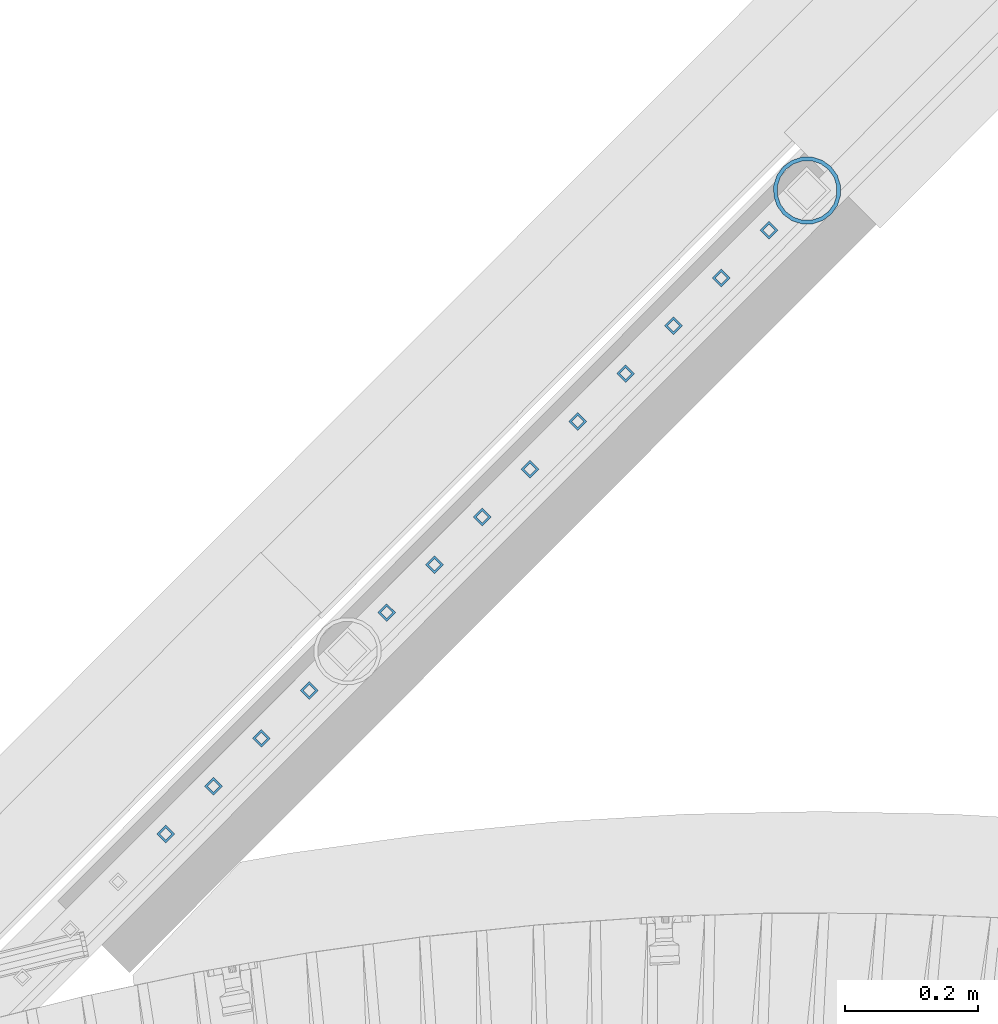
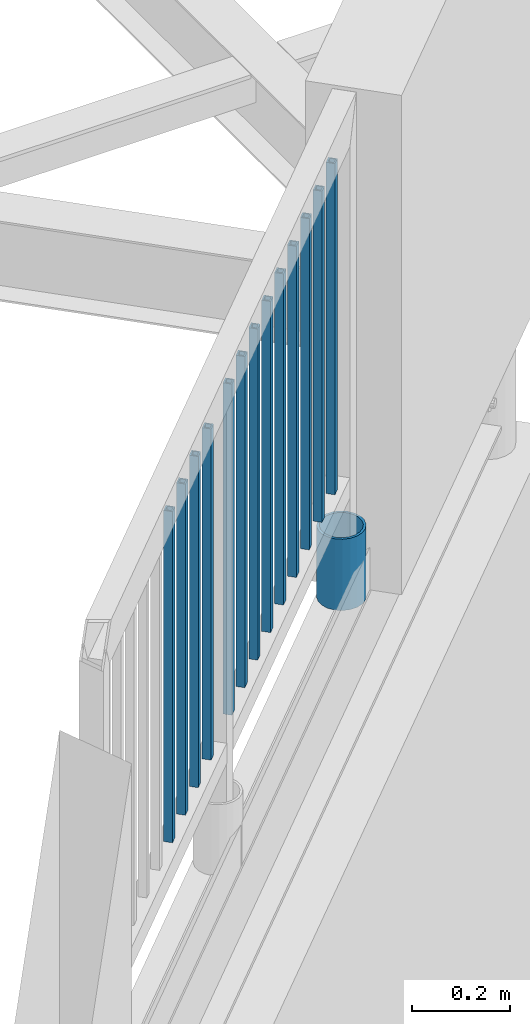
# One storey, part 273 of 975: 14 columns.
"""IFC2X3 building model written with IfcOpenShell, lengths in millimetres."""

from ifc_helpers import new_model, si_unit, frame, origin_with_axes, place, context, subcontext, project, spatial, faceted_brep, material, type_object, element, save


model = new_model("IFC2X3")

# Units and contexts
model_context = context("Model", 3, precision=1e-05, world=origin_with_axes())
body_context = subcontext(model_context, "Body", "Model", "MODEL_VIEW")
ifc_project = project(units=[si_unit("LENGTHUNIT", "METRE", prefix="MILLI"), si_unit("AREAUNIT", "SQUARE_METRE"), si_unit("VOLUMEUNIT", "CUBIC_METRE"), si_unit("MASSUNIT", "GRAM", prefix="KILO"), si_unit("TIMEUNIT", "SECOND"), si_unit("PLANEANGLEUNIT", "RADIAN"), si_unit("SOLIDANGLEUNIT", "STERADIAN"), si_unit("THERMODYNAMICTEMPERATUREUNIT", "DEGREE_CELSIUS"), si_unit("LUMINOUSINTENSITYUNIT", "LUMEN")], contexts=[model_context])

# Site, building, storey
site_placement = place(None, origin_with_axes())
site = spatial("IfcSite", under=ifc_project, at=site_placement, CompositionType="ELEMENT")
building_placement = place(site_placement, origin_with_axes())
building = spatial("IfcBuilding", under=site, at=building_placement, Name="Undefined", CompositionType="ELEMENT")
storey_placement = place(building_placement, origin_with_axes())
storey = spatial("IfcBuildingStorey", under=building, at=storey_placement, Name="Undefined", CompositionType="ELEMENT", Elevation=0.0)

# Columns
ifc_material_1 = material()
column_type_1 = type_object("IfcColumnType", Name="HSS3/4X3/4X.120_TUBES", PredefinedType="NOTDEFINED")
for number, where, z_axis, x_axis, name in (
    (1, (34659.3830095094, 9357.07291430614, 4254.50072221895), (0.706215711946904, 0.707996728946771, 0.0), (0.0, 0.0, 1.0), "PICKET"),
    (2, (34587.5486345094, 9285.23853930614, 4254.50072221895), (0.706215711946904, 0.707996728946771, 0.0), (0.0, 0.0, 1.0), "PICKET"),
    (3, (34515.7142595094, 9213.40416430614, 4254.50072221895), (0.706215711946904, 0.707996728946771, 0.0), (0.0, 0.0, 1.0), "PICKET"),
    (4, (34443.8798845094, 9141.56978930614, 4254.50072221895), (0.706215711946904, 0.707996728946771, 0.0), (0.0, 0.0, 1.0), "PICKET"),
    (5, (34372.0455095094, 9069.73541430614, 4254.50072221895), (0.706215711946904, 0.707996728946771, 0.0), (0.0, 0.0, 1.0), "PICKET"),
    (6, (34300.2111345094, 8997.90103930614, 4254.50072221895), (0.706215711946904, 0.707996728946771, 0.0), (0.0, 0.0, 1.0), "PICKET"),
    (7, (34228.3767595094, 8926.06666430614, 4254.50072221895), (0.706215711946904, 0.707996728946771, 0.0), (0.0, 0.0, 1.0), "PICKET"),
    (8, (34156.5423845094, 8854.23228930614, 4254.50072221895), (0.706215711946904, 0.707996728946771, 0.0), (0.0, 0.0, 1.0), "PICKET"),
    (9, (34084.7080095094, 8782.39791430614, 4254.50072221895), (0.706215711946904, 0.707996728946771, 0.0), (0.0, 0.0, 1.0), "PICKET"),
    (10, (33968.0490987164, 8665.44641871863, 4254.50078114725), (0.706215711946904, 0.707996728946771, 0.0), (0.0, 0.0, 1.0), "PICKET"),
    (11, (33896.2147237164, 8593.61204371863, 4254.50078114725), (0.706215711946904, 0.707996728946771, 0.0), (0.0, 0.0, 1.0), "PICKET"),
    (12, (33824.3803487164, 8521.77766871863, 4254.50078114725), (0.706215711946904, 0.707996728946771, 0.0), (0.0, 0.0, 1.0), "PICKET"),
    (13, (33752.5459737164, 8449.94329371863, 4254.50078114725), (0.706215711946904, 0.707996728946771, 0.0), (0.0, 0.0, 1.0), "PICKET"),
):
    element("IfcColumn", number, at=place(storey_placement, frame(where, z_axis=z_axis, x_axis=x_axis)), inside=storey, type_object=column_type_1, material=ifc_material_1, Name=name, ObjectType="HSS3/4X3/4X.120_TUBES", context=body_context, shape_type="Brep", body=[
        faceted_brep([(0.0, 6.34999999998763, -6.34999999998763), (0.0, -6.35000000000582, -6.34999999998763), (825.49997943247, -6.35000000000582, -6.34999999998763), (825.49997943247, 6.34999999998763, -6.34999999998763), (0.0, -6.34999999998763, 6.34999999998763), (825.49997943247, -6.34999999998763, 6.34999999998763), (0.0, 6.35000000000946, 6.34999999998763), (825.49997943247, 6.35000000000946, 6.34999999998763), (0.0, 9.52499999997963, -9.52499999997963), (0.0, 9.52500000000873, 9.5249999999869), (825.49997943247, 9.52500000000873, 9.5249999999869), (825.49997943247, 9.52499999997963, -9.52499999997963), (0.0, -9.52499999997963, 9.52499999998327), (825.49997943247, -9.52499999997963, 9.52499999998327), (0.0, -9.52500000000873, -9.5249999999869), (825.49997943247, -9.52500000000873, -9.5249999999869)], [[[0, 1, 2, 3]], [[1, 4, 5, 2]], [[4, 6, 7, 5]], [[6, 0, 3, 7]], [[8, 9, 10, 11]], [[9, 12, 13, 10]], [[12, 14, 15, 13]], [[14, 8, 11, 15]], [[13, 15, 11, 10], [5, 7, 3, 2]], [[14, 12, 9, 8], [6, 4, 1, 0]]]),
    ])
ifc_material_2 = material(Name="STEEL/A53")
column_type_2 = type_object("IfcColumnType", Name="PIPE3-1/2STD", PredefinedType="NOTDEFINED")
column_placement = place(storey_placement, frame((34716.5500466953, 9416.87062666744, 3937.00000839395), z_axis=(0.706215711946904, 0.707996728946771, 0.0), x_axis=(0.0, 0.0, 1.0)))
element("IfcColumn", 14, at=column_placement, inside=storey, type_object=column_type_2, material=ifc_material_2, ObjectType="PIPE3-1/2STD", context=body_context, shape_type="Brep", body=[
    faceted_brep([(0.0, -45.0595999999932, 1.45519152283669e-11), (0.0, -42.8542262016344, 13.924182159768), (177.8, -42.8542262016344, 13.924182159768), (177.8, -45.0595999999932, 1.45519152283669e-11), (0.0, -36.45398215971, 26.4853683542424), (177.8, -36.45398215971, 26.4853683542424), (0.0, -26.4853683541623, 36.45398215979), (177.8, -26.4853683541623, 36.45398215979), (0.0, -13.9241821596988, 42.8542262017108), (177.8, -13.9241821596988, 42.8542262017108), (0.0, 3.63797880709171e-11, 45.0596000000514), (177.8, 3.63797880709171e-11, 45.0596000000514), (0.0, 13.9241821597716, 42.8542262017036), (177.8, 13.9241821597716, 42.8542262017036), (0.0, 26.4853683542242, 36.4539821597718), (177.8, 26.4853683542242, 36.4539821597718), (0.0, 36.4539821597537, 26.4853683542206), (177.8, 36.4539821597537, 26.4853683542206), (0.0, 42.8542262016563, 13.9241821597425), (177.8, 42.8542262016563, 13.9241821597425), (0.0, 45.0595999999932, -1.09139364212751e-11), (177.8, 45.0595999999932, -1.09139364212751e-11), (0.0, 42.8542262016344, -13.9241821597643), (177.8, 42.8542262016344, -13.9241821597643), (0.0, 36.45398215971, -26.4853683542387), (177.8, 36.45398215971, -26.4853683542387), (0.0, 26.4853683541623, -36.4539821597864), (177.8, 26.4853683541623, -36.4539821597864), (0.0, 13.9241821596988, -42.8542262017072), (177.8, 13.9241821596988, -42.8542262017072), (0.0, -3.63797880709171e-11, -45.0596000000478), (177.8, -3.63797880709171e-11, -45.0596000000478), (0.0, -13.9241821597716, -42.8542262016963), (177.8, -13.9241821597716, -42.8542262016963), (0.0, -26.4853683542242, -36.4539821597682), (177.8, -26.4853683542242, -36.4539821597682), (0.0, -36.4539821597537, -26.4853683542169), (177.8, -36.4539821597537, -26.4853683542169), (0.0, -42.8542262016563, -13.9241821597352), (177.8, -42.8542262016563, -13.9241821597352), (0.0, -50.799999999992, 1.81898940354586e-11), (0.0, -48.3136710278013, -15.6980633142484), (177.8, -48.3136710278013, -15.6980633142484), (177.8, -50.799999999992, 1.81898940354586e-11), (0.0, -41.0980633142644, -29.8594908164741), (177.8, -41.0980633142644, -29.8594908164741), (0.0, -29.859490816485, -41.0980633142826), (177.8, -29.859490816485, -41.0980633142826), (0.0, -15.6980633142848, -48.313671027845), (177.8, -15.6980633142848, -48.313671027845), (0.0, -4.36557456851006e-11, -50.8000000000575), (177.8, -4.36557456851006e-11, -50.8000000000575), (0.0, 15.6980633142011, -48.3136710278523), (177.8, 15.6980633142011, -48.3136710278523), (0.0, 29.8594908164159, -41.0980633143045), (177.8, 29.8594908164159, -41.0980633143045), (0.0, 41.0980633142135, -29.8594908165032), (177.8, 41.0980633142135, -29.8594908165032), (0.0, 48.3136710277722, -15.6980633142775), (177.8, 48.3136710277722, -15.6980633142775), (0.0, 50.799999999992, -1.45519152283669e-11), (177.8, 50.799999999992, -1.45519152283669e-11), (0.0, 48.313671027794, 15.6980633142521), (177.8, 48.313671027794, 15.6980633142521), (0.0, 41.0980633142644, 29.8594908164814), (177.8, 41.0980633142644, 29.8594908164814), (0.0, 29.859490816485, 41.0980633142863), (177.8, 29.859490816485, 41.0980633142863), (0.0, 15.6980633142848, 48.3136710278486), (177.8, 15.6980633142848, 48.3136710278486), (0.0, 4.00177668780088e-11, 50.8000000000611), (177.8, 4.00177668780088e-11, 50.8000000000611), (0.0, -15.6980633142011, 48.3136710278559), (177.8, -15.6980633142011, 48.3136710278559), (0.0, -29.8594908164159, 41.0980633143081), (177.8, -29.8594908164159, 41.0980633143081), (0.0, -41.0980633142171, 29.8594908165069), (177.8, -41.0980633142171, 29.8594908165069), (0.0, -48.3136710277722, 15.6980633142812), (177.8, -48.3136710277722, 15.6980633142812)], [[[0, 1, 2, 3]], [[1, 4, 5, 2]], [[4, 6, 7, 5]], [[6, 8, 9, 7]], [[8, 10, 11, 9]], [[10, 12, 13, 11]], [[12, 14, 15, 13]], [[14, 16, 17, 15]], [[16, 18, 19, 17]], [[18, 20, 21, 19]], [[20, 22, 23, 21]], [[22, 24, 25, 23]], [[24, 26, 27, 25]], [[26, 28, 29, 27]], [[28, 30, 31, 29]], [[30, 32, 33, 31]], [[32, 34, 35, 33]], [[34, 36, 37, 35]], [[36, 38, 39, 37]], [[38, 0, 3, 39]], [[40, 41, 42, 43]], [[41, 44, 45, 42]], [[44, 46, 47, 45]], [[46, 48, 49, 47]], [[48, 50, 51, 49]], [[50, 52, 53, 51]], [[52, 54, 55, 53]], [[54, 56, 57, 55]], [[56, 58, 59, 57]], [[58, 60, 61, 59]], [[60, 62, 63, 61]], [[62, 64, 65, 63]], [[64, 66, 67, 65]], [[66, 68, 69, 67]], [[68, 70, 71, 69]], [[70, 72, 73, 71]], [[72, 74, 75, 73]], [[74, 76, 77, 75]], [[76, 78, 79, 77]], [[78, 40, 43, 79]], [[45, 47, 49, 51, 53, 55, 57, 59, 61, 63, 65, 67, 69, 71, 73, 75, 77, 79, 43, 42], [5, 7, 9, 11, 13, 15, 17, 19, 21, 23, 25, 27, 29, 31, 33, 35, 37, 39, 3, 2]], [[78, 76, 74, 72, 70, 68, 66, 64, 62, 60, 58, 56, 54, 52, 50, 48, 46, 44, 41, 40], [38, 36, 34, 32, 30, 28, 26, 24, 22, 20, 18, 16, 14, 12, 10, 8, 6, 4, 1, 0]]]),
])

save(model, "model.ifc")
